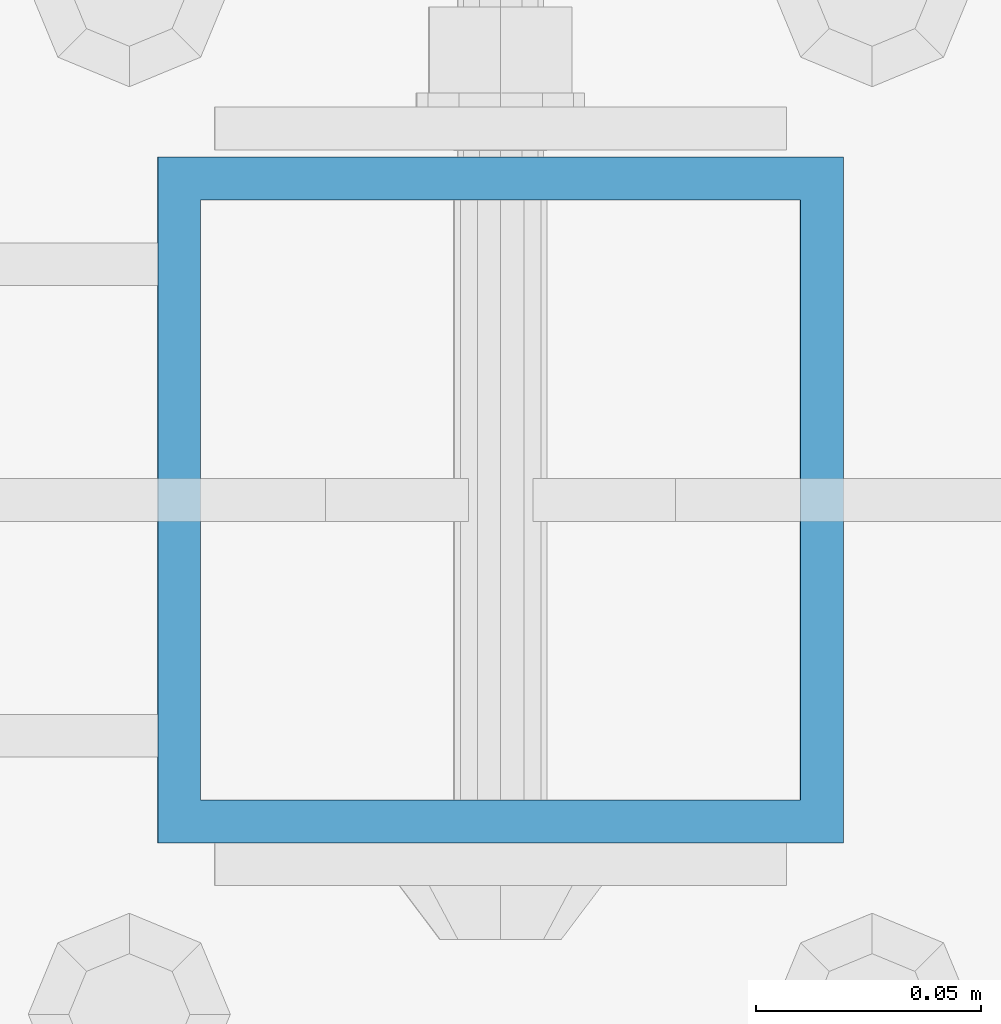
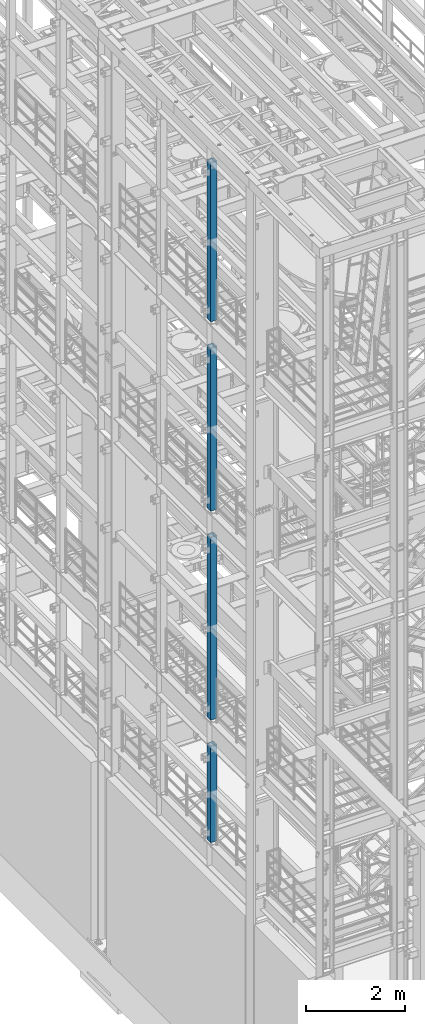
# One storey, part 622 of 1876: 4 columns, 4 elements without a shape of their own.
"""IFC2X3 building model written with IfcOpenShell, lengths in millimetres."""

from ifc_helpers import new_model, si_unit, frame, origin_with_axes, place, context, subcontext, project, spatial, faceted_brep, material, type_object, element, aggregate, save


model = new_model("IFC2X3")

# Units and contexts
model_context = context("Model", 3, precision=1e-05, world=origin_with_axes())
body_context = subcontext(model_context, "Body", "Model", "MODEL_VIEW")
ifc_project = project(units=[si_unit("LENGTHUNIT", "METRE", prefix="MILLI"), si_unit("AREAUNIT", "SQUARE_METRE"), si_unit("VOLUMEUNIT", "CUBIC_METRE"), si_unit("MASSUNIT", "GRAM", prefix="KILO"), si_unit("TIMEUNIT", "SECOND"), si_unit("PLANEANGLEUNIT", "RADIAN"), si_unit("SOLIDANGLEUNIT", "STERADIAN"), si_unit("THERMODYNAMICTEMPERATUREUNIT", "DEGREE_CELSIUS"), si_unit("LUMINOUSINTENSITYUNIT", "LUMEN")], contexts=[model_context])

# Site, building, storey
site_placement = place(None, origin_with_axes())
site = spatial("IfcSite", under=ifc_project, at=site_placement, CompositionType="ELEMENT")
building_placement = place(site_placement, origin_with_axes())
building = spatial("IfcBuilding", under=site, at=building_placement, Name="Undefined", CompositionType="ELEMENT")
storey_placement = place(building_placement, origin_with_axes())
storey = spatial("IfcBuildingStorey", under=building, at=storey_placement, Name="Undefined", CompositionType="ELEMENT", Elevation=0.0)

# Assembly, column
assembly_1_placement = place(storey_placement, origin_with_axes())
assembly_1 = element("IfcElementAssembly", 1, at=assembly_1_placement, inside=storey, Name="BEAM", AssemblyPlace="NOTDEFINED", PredefinedType="RIGID_FRAME")
ifc_material = material()
column_type = type_object("IfcColumnType", Name="HSS6X6X3/8", PredefinedType="NOTDEFINED")
column_1_placement = place(assembly_1_placement, frame((0.0, -2540.0, 17983.2), z_axis=(-1.0, 0.0, 0.0), x_axis=(0.0, 0.0, 1.0)))
column_1 = element("IfcColumn", 2, at=column_1_placement, type_object=column_type, material=ifc_material, Name="COLUMN", ObjectType="HSS6X6X3/8", context=body_context, shape_type="Brep", body=[
    faceted_brep([(12.7000000000016, 66.6750000000002, -66.6750000000002), (12.7000000000016, -66.6750000000002, -66.6750000000002), (3937.0, -66.6750000000002, -66.675), (3937.0, 66.6750000000002, -66.675), (12.7000000000016, -66.6750000000002, 66.6750000000002), (3937.0, -66.6750000000002, 66.675), (12.7000000000016, 66.6750000000002, 66.6750000000002), (3937.0, 66.6750000000002, 66.675), (12.7000000000016, 76.1999999999998, -76.1999999999998), (12.7000000000016, 76.1999999999998, 76.1999999999998), (3937.0, 76.1999999999998, 76.2), (3937.0, 76.1999999999998, -76.2), (12.7000000000016, -76.1999999999998, 76.1999999999998), (3937.0, -76.1999999999998, 76.2), (12.7000000000016, -76.1999999999998, -76.1999999999998), (3937.0, -76.1999999999998, -76.2)], [[[0, 1, 2, 3]], [[1, 4, 5, 2]], [[4, 6, 7, 5]], [[6, 0, 3, 7]], [[8, 9, 10, 11]], [[9, 12, 13, 10]], [[12, 14, 15, 13]], [[14, 8, 11, 15]], [[13, 15, 11, 10], [5, 7, 3, 2]], [[14, 12, 9, 8], [6, 4, 1, 0]]]),
])
aggregate(assembly_1, [column_1])

assembly_2_placement = place(storey_placement, origin_with_axes())
assembly_2 = element("IfcElementAssembly", 3, at=assembly_2_placement, inside=storey, Name="BEAM", AssemblyPlace="NOTDEFINED", PredefinedType="RIGID_FRAME")
column_2_placement = place(assembly_2_placement, frame((0.0, -2540.0, 13309.6), z_axis=(-1.0, 0.0, 0.0), x_axis=(0.0, 0.0, 1.0)))
column_2 = element("IfcColumn", 4, at=column_2_placement, type_object=column_type, material=ifc_material, Name="COLUMN", ObjectType="HSS6X6X3/8", context=body_context, shape_type="Brep", body=[
    faceted_brep([(12.7000000000016, 66.6750000000002, -66.6750000000002), (12.7000000000016, -66.6750000000002, -66.6750000000002), (4038.6, -66.6750000000002, -66.675), (4038.6, 66.6750000000002, -66.675), (12.7000000000016, -66.6750000000002, 66.6750000000002), (4038.6, -66.6750000000002, 66.675), (12.7000000000016, 66.6750000000002, 66.6750000000002), (4038.6, 66.6750000000002, 66.675), (12.7000000000016, 76.1999999999998, -76.1999999999998), (12.7000000000016, 76.1999999999998, 76.1999999999998), (4038.6, 76.1999999999998, 76.2), (4038.6, 76.1999999999998, -76.2), (12.7000000000016, -76.1999999999998, 76.1999999999998), (4038.6, -76.1999999999998, 76.2), (12.7000000000016, -76.1999999999998, -76.1999999999998), (4038.6, -76.1999999999998, -76.2)], [[[0, 1, 2, 3]], [[1, 4, 5, 2]], [[4, 6, 7, 5]], [[6, 0, 3, 7]], [[8, 9, 10, 11]], [[9, 12, 13, 10]], [[12, 14, 15, 13]], [[14, 8, 11, 15]], [[13, 15, 11, 10], [5, 7, 3, 2]], [[14, 12, 9, 8], [6, 4, 1, 0]]]),
])
aggregate(assembly_2, [column_2])

assembly_3_placement = place(storey_placement, origin_with_axes())
assembly_3 = element("IfcElementAssembly", 5, at=assembly_3_placement, inside=storey, Name="BEAM", AssemblyPlace="NOTDEFINED", PredefinedType="RIGID_FRAME")
column_3_placement = place(assembly_3_placement, frame((0.0, -2540.0, 8153.4), z_axis=(-0.999999999563517, 0.0, -2.95459999870218e-05), x_axis=(-2.95459999861759e-05, 0.0, 0.999999999563517)))
column_3 = element("IfcColumn", 6, at=column_3_placement, type_object=column_type, material=ifc_material, Name="COLUMN", ObjectType="HSS6X6X3/8", context=body_context, shape_type="Brep", body=[
    faceted_brep([(12.698030025992, 66.6750000000002, -66.675), (12.698030025992, -66.6750000000002, -66.675), (4521.2007045434, -66.6750000000002, -66.675), (4521.2007045434, 66.6750000000002, -66.675), (12.7019699850925, -66.6750000000002, 66.675), (4521.20070454334, -66.6750000000002, 66.675), (12.7019699850925, 66.6750000000002, 66.675), (4521.20070454334, 66.6750000000002, 66.675), (12.6977486003425, 76.1999999999998, -76.2), (12.7022514107421, 76.1999999999998, 76.2), (4521.20070454334, 76.1999999999998, 76.2), (4521.2007045434, 76.1999999999998, -76.2), (12.7022514107421, -76.1999999999998, 76.2), (4521.20070454334, -76.1999999999998, 76.2), (12.6977486003425, -76.1999999999998, -76.2), (4521.2007045434, -76.1999999999998, -76.2)], [[[0, 1, 2, 3]], [[1, 4, 5, 2]], [[4, 6, 7, 5]], [[6, 0, 3, 7]], [[8, 9, 10, 11]], [[9, 12, 13, 10]], [[12, 14, 15, 13]], [[14, 8, 11, 15]], [[13, 15, 11, 10], [5, 7, 3, 2]], [[14, 12, 9, 8], [6, 4, 1, 0]]]),
])
aggregate(assembly_3, [column_3])

assembly_4_placement = place(storey_placement, origin_with_axes())
assembly_4 = element("IfcElementAssembly", 7, at=assembly_4_placement, inside=storey, Name="BEAM", AssemblyPlace="NOTDEFINED", PredefinedType="RIGID_FRAME")
column_4_placement = place(assembly_4_placement, frame((0.0, -2540.0, 5130.8), z_axis=(-0.999999998434855, 0.0, -5.59490000241567e-05), x_axis=(-5.59490000243298e-05, 0.0, 0.999999998434855)))
column_4 = element("IfcColumn", 8, at=column_4_placement, type_object=column_type, material=ifc_material, Name="COLUMN", ObjectType="HSS6X6X3/8", context=body_context, shape_type="Brep", body=[
    faceted_brep([(12.6962696202891, 66.6750000000002, -66.675), (12.6962696202891, -66.6750000000002, -66.675), (2387.60070630699, -66.6750000000002, -66.675), (2387.60070630699, 66.6750000000002, -66.675), (12.7037304194646, -66.6750000000002, 66.675), (2387.600706307, -66.6750000000002, 66.675), (12.7037304194646, 66.6750000000002, 66.675), (2387.600706307, 66.6750000000002, 66.675), (12.6957367060613, 76.1999999999998, -76.2), (12.7042633336914, 76.1999999999998, 76.2), (2387.600706307, 76.1999999999998, 76.2), (2387.60070630699, 76.1999999999998, -76.2), (12.7042633336914, -76.1999999999998, 76.2), (2387.600706307, -76.1999999999998, 76.2), (12.6957367060613, -76.1999999999998, -76.2), (2387.60070630699, -76.1999999999998, -76.2)], [[[0, 1, 2, 3]], [[1, 4, 5, 2]], [[4, 6, 7, 5]], [[6, 0, 3, 7]], [[8, 9, 10, 11]], [[9, 12, 13, 10]], [[12, 14, 15, 13]], [[14, 8, 11, 15]], [[13, 15, 11, 10], [5, 7, 3, 2]], [[14, 12, 9, 8], [6, 4, 1, 0]]]),
])
aggregate(assembly_4, [column_4])

save(model, "model.ifc")
